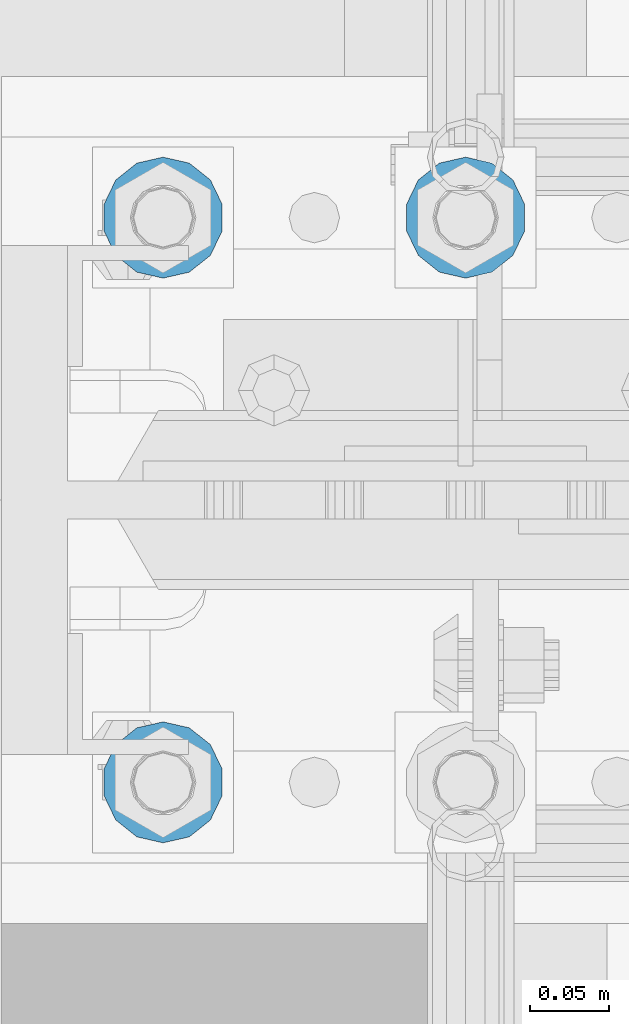
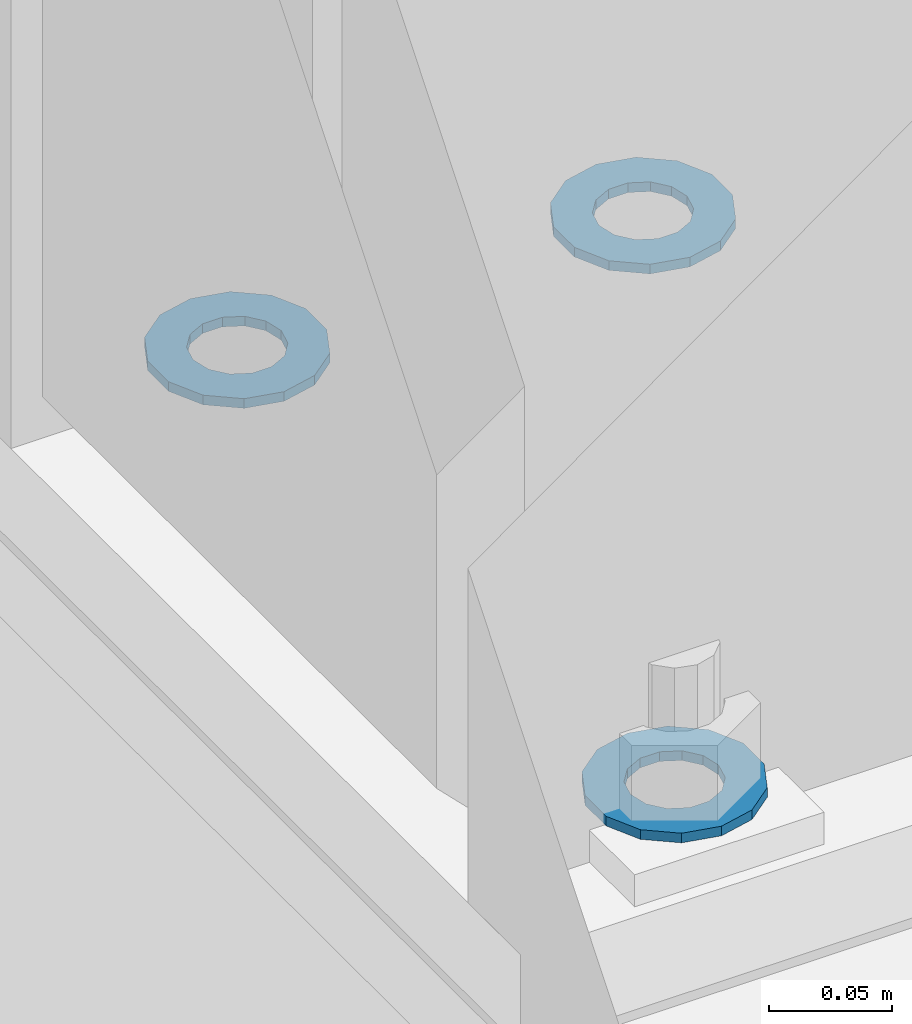
# One storey, part 817 of 1876: 3 columns, 1 element without a shape of its own.
"""IFC2X3 building model written with IfcOpenShell, lengths in millimetres."""

import ifcopenshell
import ifcopenshell.guid

model = None  # the IFC model being written
_history = None  # IfcOwnerHistory: only IFC2X3 demands one
_inside = {}  # id of a spatial element -> (the spatial element, [elements in it])
_under = {}  # id of a project, library or spatial element -> (it, [spatial elements below it])
_declared = {}  # id of a project -> (the project, [libraries it declares])
_typed = {}  # id of a type object -> (the type object, [elements of that type])
_made_of = {}  # id of a material, layer set ... -> (it, [elements and type objects made of it])


def new_model(schema):
    """Start an empty IFC model of exactly this schema.

    Asked for "IFC4X3", IfcOpenShell would pick the latest addendum, in which some entities
    have other attributes; the version numbers below select the first issue.
    IFC2X3 requires an IfcOwnerHistory on every rooted entity: one is made here for all.
    """
    global model, _history
    if schema == "IFC4X3":
        model = ifcopenshell.file(schema_version=(4, 3, 0, 0))
    else:
        model = ifcopenshell.file(schema=schema)
    _inside.clear()
    _under.clear()
    _declared.clear()
    _typed.clear()
    _made_of.clear()
    _history = None
    if model.schema == "IFC2X3":
        org = make("IfcOrganization", Name="unknown")
        user = make(
            "IfcPersonAndOrganization",
            ThePerson=make("IfcPerson", FamilyName="unknown"),
            TheOrganization=org,
        )
        app = make(
            "IfcApplication",
            ApplicationDeveloper=org,
            Version="unknown",
            ApplicationFullName="unknown",
            ApplicationIdentifier="unknown",
        )
        _history = make(
            "IfcOwnerHistory",
            OwningUser=user,
            OwningApplication=app,
            ChangeAction="ADDED",
            CreationDate=0,
        )
    return model


def make(cls, **values):
    """One entity of the class cls with the attributes given. An attribute that is None is left unset."""
    return model.create_entity(
        cls, **{name: value for name, value in values.items() if value is not None}
    )


def rooted(cls, **values):
    """An entity with a GlobalId (a new one), such as an element, a storey or a relation."""
    return make(cls, GlobalId=ifcopenshell.guid.new(), OwnerHistory=_history, **values)


def si_unit(unit_type, name, prefix=None):
    """IfcSIUnit, for example si_unit("LENGTHUNIT", "METRE", prefix="MILLI")."""
    return make("IfcSIUnit", UnitType=unit_type, Prefix=prefix, Name=name)


def assignment(units):
    """IfcUnitAssignment: the units of a project."""
    return None if units is None else make("IfcUnitAssignment", Units=units)


def point(xyz):
    """IfcCartesianPoint."""
    return None if xyz is None else make("IfcCartesianPoint", Coordinates=xyz)


def direction(xyz):
    """IfcDirection."""
    return None if xyz is None else make("IfcDirection", DirectionRatios=xyz)


def frame(location, z_axis=None, x_axis=None):
    """IfcAxis2Placement3D, a coordinate frame: its origin and axes. An axis left out is left unset."""
    return make(
        "IfcAxis2Placement3D",
        Location=point(location),
        Axis=direction(z_axis),
        RefDirection=direction(x_axis),
    )


def origin_with_axes():
    """The frame at (0, 0, 0) with the z axis (0, 0, 1) and the x axis (1, 0, 0) written out."""
    return frame((0.0, 0.0, 0.0), z_axis=(0.0, 0.0, 1.0), x_axis=(1.0, 0.0, 0.0))


def place(relative_to, where):
    """IfcLocalPlacement: puts the frame where relative to a parent placement (None: the world)."""
    return make(
        "IfcLocalPlacement", PlacementRelTo=relative_to, RelativePlacement=where
    )


def context(
    kind, dimensions, precision=None, world=None, true_north=None, identifier=None
):
    """IfcGeometricRepresentationContext, for example the 3D "Model" context."""
    return make(
        "IfcGeometricRepresentationContext",
        ContextIdentifier=identifier,
        ContextType=kind,
        CoordinateSpaceDimension=dimensions,
        Precision=precision,
        WorldCoordinateSystem=world,
        TrueNorth=true_north,
    )


def subcontext(parent, identifier, kind, view, scale=None):
    """IfcGeometricRepresentationSubContext, for example "Body" below "Model"."""
    return make(
        "IfcGeometricRepresentationSubContext",
        ContextIdentifier=identifier,
        ContextType=kind,
        ParentContext=parent,
        TargetScale=scale,
        TargetView=view,
    )


def project(units=None, contexts=None):
    """IfcProject with its units and contexts."""
    return rooted(
        "IfcProject",
        Name="project",
        RepresentationContexts=contexts,
        UnitsInContext=assignment(units),
    )


def spatial(cls, under=None, at=None, **own):
    """A site, building, storey or space (cls), placed at a placement, below another one or the project."""
    s = rooted(cls, ObjectPlacement=at, **own)
    if under is not None:
        _under.setdefault(under.id(), (under, []))[1].append(s)
    return s


def faces_of(points, faces, orient=None, outer=None):
    """IfcFace entities. A face is a list of loops; a loop is a list of indices into points, from 0.

    orient and outer hold one flag for each loop. By default every Orientation is true, the
    first loop of a face is its IfcFaceOuterBound and the others are IfcFaceBound.
    """
    made = []
    for i, loops in enumerate(faces):
        bounds = []
        for j, loop in enumerate(loops):
            is_outer = j == 0 if outer is None else outer[i][j]
            bounds.append(
                make(
                    "IfcFaceOuterBound" if is_outer else "IfcFaceBound",
                    Bound=make("IfcPolyLoop", Polygon=[points[k] for k in loop]),
                    Orientation=True if orient is None else orient[i][j],
                )
            )
        made.append(make("IfcFace", Bounds=bounds))
    return made


def faceted_brep(points, faces, orient=None, outer=None, voids=None):
    """IfcFacetedBrep: a solid bounded by flat faces; with voids (closed shells), ...WithVoids."""
    shared = [point(p) for p in points]
    hull = make("IfcClosedShell", CfsFaces=faces_of(shared, faces, orient, outer))
    if voids is None:
        return make("IfcFacetedBrep", Outer=hull)
    return make(
        "IfcFacetedBrepWithVoids",
        Outer=hull,
        Voids=[
            make(cls, CfsFaces=faces_of(shared, fs, o, b)) for cls, fs, o, b in voids
        ],
    )


def shape(context_of_items, identifier, shape_type, items):
    """IfcShapeRepresentation: the items that make up one representation, for example the "Body"."""
    return make(
        "IfcShapeRepresentation",
        ContextOfItems=context_of_items,
        RepresentationIdentifier=identifier,
        RepresentationType=shape_type,
        Items=items,
    )


def material(Name=None, Category=None):
    """IfcMaterial."""
    return make("IfcMaterial", Name=Name, Category=Category)


def made_of(thing, what):
    """Note that an element or type object is made of a material, layer set ...; save() writes the relation."""
    if what is not None:
        _made_of.setdefault(what.id(), (what, []))[1].append(thing)
    return thing


def type_object(cls, material=None, **own):
    """A type object (cls), such as IfcWallType, which elements share."""
    return made_of(rooted(cls, **own), material)


def element(
    cls,
    number,
    at=None,
    inside=None,
    cuts=None,
    type_object=None,
    material=None,
    context=None,
    identifier="Body",
    shape_type=None,
    held_by="IfcProductDefinitionShape",
    body=None,
    shapes=None,
    **own,
):
    """One element of the class cls, such as IfcWall. Its Tag is "e" and its number.

    at: its placement. inside: the storey or other place that contains it. cuts: it is an
    opening in that element (IfcRelVoidsElement). A single representation is given by context,
    identifier, shape_type and body (its items); several are given by shapes. held_by: the class
    of the entity that holds the representations. save() writes the other relations.
    """
    e = rooted(cls, Tag="e%d" % number, ObjectPlacement=at, **own)
    if body is not None:
        shapes = [shape(context, identifier, shape_type, body)]
    if shapes is not None:
        e.Representation = make(held_by, Representations=shapes)
    if inside is not None:
        _inside.setdefault(inside.id(), (inside, []))[1].append(e)
    if cuts is not None:
        rooted(
            "IfcRelVoidsElement", RelatingBuildingElement=cuts, RelatedOpeningElement=e
        )
    if type_object is not None:
        _typed.setdefault(type_object.id(), (type_object, []))[1].append(e)
    return made_of(e, material)


def aggregate(whole, parts):
    """IfcRelAggregates: a whole, such as a stair, and the parts it consists of."""
    return rooted("IfcRelAggregates", RelatingObject=whole, RelatedObjects=parts)


def save(model, path):
    """Write the relations noted so far, then the file.

    IfcRelAggregates (storeys below a building ...), IfcRelContainedInSpatialStructure (elements
    in a storey), IfcRelDefinesByType, IfcRelAssociatesMaterial and IfcRelDeclares: one each for
    every whole, place, type object, material and project.
    """
    for whole, parts in _under.values():
        aggregate(whole, parts)
    for where, things in _inside.values():
        rooted(
            "IfcRelContainedInSpatialStructure",
            RelatedElements=things,
            RelatingStructure=where,
        )
    for kind, things in _typed.values():
        rooted("IfcRelDefinesByType", RelatedObjects=things, RelatingType=kind)
    for what, things in _made_of.values():
        rooted("IfcRelAssociatesMaterial", RelatedObjects=things, RelatingMaterial=what)
    for by, libraries in _declared.values():
        rooted("IfcRelDeclares", RelatingContext=by, RelatedDefinitions=libraries)
    model.write(path)


model = new_model("IFC2X3")

# Units and contexts
model_context = context("Model", 3, precision=1e-05, world=origin_with_axes())
body_context = subcontext(model_context, "Body", "Model", "MODEL_VIEW")
ifc_project = project(units=[si_unit("LENGTHUNIT", "METRE", prefix="MILLI"), si_unit("AREAUNIT", "SQUARE_METRE"), si_unit("VOLUMEUNIT", "CUBIC_METRE"), si_unit("MASSUNIT", "GRAM", prefix="KILO"), si_unit("TIMEUNIT", "SECOND"), si_unit("PLANEANGLEUNIT", "RADIAN"), si_unit("SOLIDANGLEUNIT", "STERADIAN"), si_unit("THERMODYNAMICTEMPERATUREUNIT", "DEGREE_CELSIUS"), si_unit("LUMINOUSINTENSITYUNIT", "LUMEN")], contexts=[model_context])

# Site, building, storey
site_placement = place(None, origin_with_axes())
site = spatial("IfcSite", under=ifc_project, at=site_placement, CompositionType="ELEMENT")
building_placement = place(site_placement, origin_with_axes())
building = spatial("IfcBuilding", under=site, at=building_placement, Name="Undefined", CompositionType="ELEMENT")
storey_placement = place(building_placement, origin_with_axes())
storey = spatial("IfcBuildingStorey", under=building, at=storey_placement, Name="Undefined", CompositionType="ELEMENT", Elevation=0.0)

# Assembly, columns
assembly_placement = place(storey_placement, origin_with_axes())
assembly = element("IfcElementAssembly", 1, at=assembly_placement, inside=storey, Name="TEMPLATE", AssemblyPlace="NOTDEFINED", PredefinedType="RIGID_FRAME")
ifc_material = material(Name="STEEL/F436")
column_type = type_object("IfcColumnType", Name="1-1/2_WASHER", PredefinedType="NOTDEFINED")
column_1_placement = place(assembly_placement, frame((-2.8421709430404e-14, -4394.2, 109.5375), z_axis=(-1.0, 0.0, 0.0), x_axis=(0.0, 0.0, -1.0)))
column_1 = element("IfcColumn", 2, at=column_1_placement, type_object=column_type, material=ifc_material, Name="WASHER", ObjectType="1-1/2_WASHER", context=body_context, shape_type="Brep", body=[
    faceted_brep([(0.0, -38.0999984741211, 0.0), (0.0, -34.3269124923136, -16.5309697983251), (4.7625, -34.3269124923136, -16.5309697983251), (4.7625, -38.0999984741211, 0.0), (0.0, -23.7549604994474, -29.787778289052), (4.7625, -23.7549604994474, -29.787778289052), (0.0, -8.4780472441962, -37.1447519665058), (4.7625, -8.4780472441962, -37.1447519665058), (0.0, 8.4780472441962, -37.1447519665058), (4.7625, 8.4780472441962, -37.1447519665058), (0.0, 23.7549604994474, -29.787778289052), (4.7625, 23.7549604994474, -29.787778289052), (0.0, 34.3269124923136, -16.5309697983251), (4.7625, 34.3269124923136, -16.5309697983251), (0.0, 38.0999984741211, 0.0), (4.7625, 38.0999984741211, 0.0), (0.0, 34.3269124923136, 16.5309697983251), (4.7625, 34.3269124923136, 16.5309697983251), (0.0, 23.7549604994474, 29.787778289052), (4.7625, 23.7549604994474, 29.787778289052), (0.0, 8.4780472441962, 37.1447519665058), (4.7625, 8.4780472441962, 37.1447519665058), (0.0, -8.4780472441962, 37.1447519665058), (4.7625, -8.4780472441962, 37.1447519665058), (0.0, -23.7549604994474, 29.787778289052), (4.7625, -23.7549604994474, 29.787778289052), (0.0, -34.3269124923136, 16.5309697983251), (4.7625, -34.3269124923136, 16.5309697983251), (0.0, 0.0, 20.6399993896484), (0.0, 8.95536011056538, 18.5959968835978), (4.7625, 8.95536011056538, 18.595996883598), (4.7625, 0.0, 20.6399993896484), (0.0, 16.1370013209489, 12.8688291298158), (4.7625, 16.1370013209489, 12.8688291298162), (0.0, 20.1225115123834, 4.59283194104228), (4.7625, 20.1225115123834, 4.59283194104222), (0.0, 20.1225115123834, -4.59283194104228), (4.7625, 20.1225115123834, -4.59283194104242), (0.0, 16.1370013209489, -12.8688291298167), (4.7625, 16.1370013209489, -12.8688291298163), (0.0, 8.95536011056538, -18.5959968835978), (4.7625, 8.95536011056538, -18.5959968835982), (0.0, 0.0, -20.6399993896484), (4.7625, 0.0, -20.6399993896484), (0.0, -8.95536011056538, -18.5959968835978), (4.7625, -8.95536011056538, -18.595996883598), (0.0, -16.1370013209489, -12.8688291298158), (4.7625, -16.1370013209489, -12.8688291298162), (0.0, -20.1225115123834, -4.59283194104228), (4.7625, -20.1225115123834, -4.59283194104222), (0.0, -20.1225115123834, 4.59283194104228), (4.7625, -20.1225115123834, 4.59283194104242), (0.0, -16.1370013209489, 12.8688291298167), (4.7625, -16.1370013209489, 12.8688291298163), (0.0, -8.95536011056538, 18.5959968835978), (4.7625, -8.95536011056538, 18.5959968835982)], [[[0, 1, 2, 3]], [[1, 4, 5, 2]], [[4, 6, 7, 5]], [[6, 8, 9, 7]], [[8, 10, 11, 9]], [[10, 12, 13, 11]], [[12, 14, 15, 13]], [[14, 16, 17, 15]], [[16, 18, 19, 17]], [[18, 20, 21, 19]], [[20, 22, 23, 21]], [[22, 24, 25, 23]], [[24, 26, 27, 25]], [[26, 0, 3, 27]], [[28, 29, 30, 31]], [[29, 32, 33, 30]], [[32, 34, 35, 33]], [[34, 36, 37, 35]], [[36, 38, 39, 37]], [[38, 40, 41, 39]], [[40, 42, 43, 41]], [[42, 44, 45, 43]], [[44, 46, 47, 45]], [[46, 48, 49, 47]], [[48, 50, 51, 49]], [[50, 52, 53, 51]], [[52, 54, 55, 53]], [[54, 28, 31, 55]], [[5, 7, 9, 11, 13, 15, 17, 19, 21, 23, 25, 27, 3, 2], [33, 35, 37, 39, 41, 43, 45, 47, 49, 51, 53, 55, 31, 30]], [[26, 24, 22, 20, 18, 16, 14, 12, 10, 8, 6, 4, 1, 0], [54, 52, 50, 48, 46, 44, 42, 40, 38, 36, 34, 32, 29, 28]]]),
])
column_2_placement = place(assembly_placement, frame((-190.5, -4749.8, 109.5375), z_axis=(1.0, 0.0, 0.0), x_axis=(0.0, 0.0, -1.0)))
column_2 = element("IfcColumn", 3, at=column_2_placement, type_object=column_type, material=ifc_material, Name="WASHER", ObjectType="1-1/2_WASHER", context=body_context, shape_type="Brep", body=[
    faceted_brep([(0.0, -38.0999984741211, 0.0), (0.0, -34.3269124923136, -16.5309697983251), (4.7625, -34.3269124923136, -16.5309697983251), (4.7625, -38.0999984741211, 0.0), (0.0, -23.7549604994474, -29.787778289052), (4.7625, -23.7549604994474, -29.787778289052), (0.0, -8.4780472441962, -37.1447519665058), (4.7625, -8.4780472441962, -37.1447519665058), (0.0, 8.4780472441962, -37.1447519665058), (4.7625, 8.4780472441962, -37.1447519665058), (0.0, 23.7549604994474, -29.787778289052), (4.7625, 23.7549604994474, -29.787778289052), (0.0, 34.3269124923136, -16.5309697983251), (4.7625, 34.3269124923136, -16.5309697983251), (0.0, 38.0999984741211, 0.0), (4.7625, 38.0999984741211, 0.0), (0.0, 34.3269124923136, 16.5309697983251), (4.7625, 34.3269124923136, 16.5309697983251), (0.0, 23.7549604994474, 29.787778289052), (4.7625, 23.7549604994474, 29.787778289052), (0.0, 8.4780472441962, 37.1447519665058), (4.7625, 8.4780472441962, 37.1447519665058), (0.0, -8.4780472441962, 37.1447519665058), (4.7625, -8.4780472441962, 37.1447519665058), (0.0, -23.7549604994474, 29.787778289052), (4.7625, -23.7549604994474, 29.787778289052), (0.0, -34.3269124923136, 16.5309697983251), (4.7625, -34.3269124923136, 16.5309697983251), (0.0, 0.0, 20.6399993896484), (0.0, 8.95536011056538, 18.5959968835978), (4.7625, 8.95536011056538, 18.595996883598), (4.7625, 0.0, 20.6399993896484), (0.0, 16.1370013209489, 12.8688291298158), (4.7625, 16.1370013209489, 12.8688291298162), (0.0, 20.1225115123834, 4.59283194104228), (4.7625, 20.1225115123834, 4.59283194104222), (0.0, 20.1225115123834, -4.59283194104228), (4.7625, 20.1225115123834, -4.59283194104242), (0.0, 16.1370013209489, -12.8688291298167), (4.7625, 16.1370013209489, -12.8688291298163), (0.0, 8.95536011056538, -18.5959968835978), (4.7625, 8.95536011056538, -18.5959968835982), (0.0, 0.0, -20.6399993896484), (4.7625, 0.0, -20.6399993896484), (0.0, -8.95536011056538, -18.5959968835978), (4.7625, -8.95536011056538, -18.595996883598), (0.0, -16.1370013209489, -12.8688291298158), (4.7625, -16.1370013209489, -12.8688291298162), (0.0, -20.1225115123834, -4.59283194104228), (4.7625, -20.1225115123834, -4.59283194104222), (0.0, -20.1225115123834, 4.59283194104228), (4.7625, -20.1225115123834, 4.59283194104242), (0.0, -16.1370013209489, 12.8688291298167), (4.7625, -16.1370013209489, 12.8688291298163), (0.0, -8.95536011056538, 18.5959968835978), (4.7625, -8.95536011056538, 18.5959968835982)], [[[0, 1, 2, 3]], [[1, 4, 5, 2]], [[4, 6, 7, 5]], [[6, 8, 9, 7]], [[8, 10, 11, 9]], [[10, 12, 13, 11]], [[12, 14, 15, 13]], [[14, 16, 17, 15]], [[16, 18, 19, 17]], [[18, 20, 21, 19]], [[20, 22, 23, 21]], [[22, 24, 25, 23]], [[24, 26, 27, 25]], [[26, 0, 3, 27]], [[28, 29, 30, 31]], [[29, 32, 33, 30]], [[32, 34, 35, 33]], [[34, 36, 37, 35]], [[36, 38, 39, 37]], [[38, 40, 41, 39]], [[40, 42, 43, 41]], [[42, 44, 45, 43]], [[44, 46, 47, 45]], [[46, 48, 49, 47]], [[48, 50, 51, 49]], [[50, 52, 53, 51]], [[52, 54, 55, 53]], [[54, 28, 31, 55]], [[5, 7, 9, 11, 13, 15, 17, 19, 21, 23, 25, 27, 3, 2], [33, 35, 37, 39, 41, 43, 45, 47, 49, 51, 53, 55, 31, 30]], [[26, 24, 22, 20, 18, 16, 14, 12, 10, 8, 6, 4, 1, 0], [54, 52, 50, 48, 46, 44, 42, 40, 38, 36, 34, 32, 29, 28]]]),
])
column_3_placement = place(assembly_placement, frame((-190.5, -4394.2, 109.5375), z_axis=(-1.0, 0.0, 0.0), x_axis=(0.0, 0.0, -1.0)))
column_3 = element("IfcColumn", 4, at=column_3_placement, type_object=column_type, material=ifc_material, Name="WASHER", ObjectType="1-1/2_WASHER", context=body_context, shape_type="Brep", body=[
    faceted_brep([(0.0, -38.0999984741211, 0.0), (0.0, -34.3269124923136, -16.5309697983251), (4.7625, -34.3269124923136, -16.5309697983251), (4.7625, -38.0999984741211, 0.0), (0.0, -23.7549604994474, -29.787778289052), (4.7625, -23.7549604994474, -29.787778289052), (0.0, -8.4780472441962, -37.1447519665058), (4.7625, -8.4780472441962, -37.1447519665058), (0.0, 8.4780472441962, -37.1447519665058), (4.7625, 8.4780472441962, -37.1447519665058), (0.0, 23.7549604994474, -29.787778289052), (4.7625, 23.7549604994474, -29.787778289052), (0.0, 34.3269124923136, -16.5309697983251), (4.7625, 34.3269124923136, -16.5309697983251), (0.0, 38.0999984741211, 0.0), (4.7625, 38.0999984741211, 0.0), (0.0, 34.3269124923136, 16.5309697983251), (4.7625, 34.3269124923136, 16.5309697983251), (0.0, 23.7549604994474, 29.787778289052), (4.7625, 23.7549604994474, 29.787778289052), (0.0, 8.4780472441962, 37.1447519665058), (4.7625, 8.4780472441962, 37.1447519665058), (0.0, -8.4780472441962, 37.1447519665058), (4.7625, -8.4780472441962, 37.1447519665058), (0.0, -23.7549604994474, 29.787778289052), (4.7625, -23.7549604994474, 29.787778289052), (0.0, -34.3269124923136, 16.5309697983251), (4.7625, -34.3269124923136, 16.5309697983251), (0.0, 0.0, 20.6399993896484), (0.0, 8.95536011056538, 18.5959968835978), (4.7625, 8.95536011056538, 18.595996883598), (4.7625, 0.0, 20.6399993896484), (0.0, 16.1370013209489, 12.8688291298158), (4.7625, 16.1370013209489, 12.8688291298162), (0.0, 20.1225115123834, 4.59283194104228), (4.7625, 20.1225115123834, 4.59283194104222), (0.0, 20.1225115123834, -4.59283194104228), (4.7625, 20.1225115123834, -4.59283194104242), (0.0, 16.1370013209489, -12.8688291298167), (4.7625, 16.1370013209489, -12.8688291298163), (0.0, 8.95536011056538, -18.5959968835978), (4.7625, 8.95536011056538, -18.5959968835982), (0.0, 0.0, -20.6399993896484), (4.7625, 0.0, -20.6399993896484), (0.0, -8.95536011056538, -18.5959968835978), (4.7625, -8.95536011056538, -18.595996883598), (0.0, -16.1370013209489, -12.8688291298158), (4.7625, -16.1370013209489, -12.8688291298162), (0.0, -20.1225115123834, -4.59283194104228), (4.7625, -20.1225115123834, -4.59283194104222), (0.0, -20.1225115123834, 4.59283194104228), (4.7625, -20.1225115123834, 4.59283194104242), (0.0, -16.1370013209489, 12.8688291298167), (4.7625, -16.1370013209489, 12.8688291298163), (0.0, -8.95536011056538, 18.5959968835978), (4.7625, -8.95536011056538, 18.5959968835982)], [[[0, 1, 2, 3]], [[1, 4, 5, 2]], [[4, 6, 7, 5]], [[6, 8, 9, 7]], [[8, 10, 11, 9]], [[10, 12, 13, 11]], [[12, 14, 15, 13]], [[14, 16, 17, 15]], [[16, 18, 19, 17]], [[18, 20, 21, 19]], [[20, 22, 23, 21]], [[22, 24, 25, 23]], [[24, 26, 27, 25]], [[26, 0, 3, 27]], [[28, 29, 30, 31]], [[29, 32, 33, 30]], [[32, 34, 35, 33]], [[34, 36, 37, 35]], [[36, 38, 39, 37]], [[38, 40, 41, 39]], [[40, 42, 43, 41]], [[42, 44, 45, 43]], [[44, 46, 47, 45]], [[46, 48, 49, 47]], [[48, 50, 51, 49]], [[50, 52, 53, 51]], [[52, 54, 55, 53]], [[54, 28, 31, 55]], [[5, 7, 9, 11, 13, 15, 17, 19, 21, 23, 25, 27, 3, 2], [33, 35, 37, 39, 41, 43, 45, 47, 49, 51, 53, 55, 31, 30]], [[26, 24, 22, 20, 18, 16, 14, 12, 10, 8, 6, 4, 1, 0], [54, 52, 50, 48, 46, 44, 42, 40, 38, 36, 34, 32, 29, 28]]]),
])
aggregate(assembly, [column_1, column_2, column_3])

save(model, "model.ifc")
